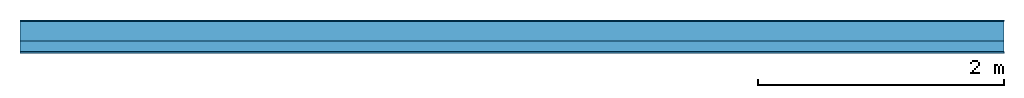
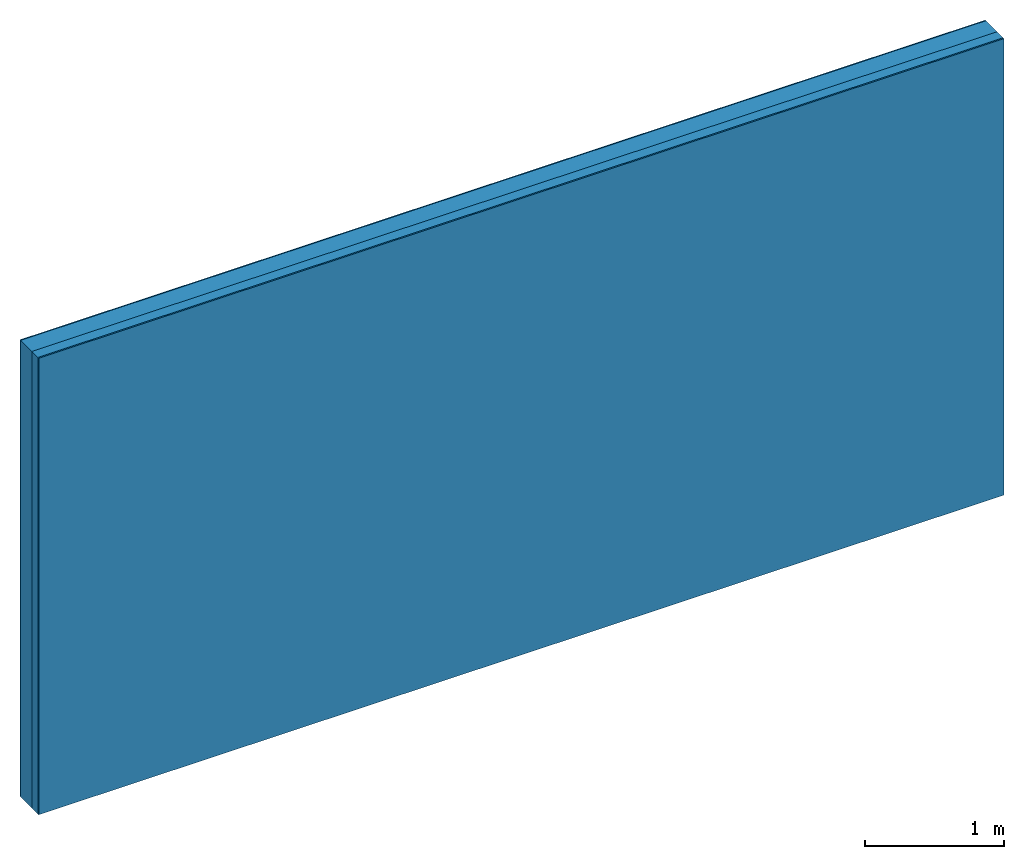
# One storey: 3 plates, 1 member, 1 element without a shape of its own.
"""IFC4 building model written with IfcOpenShell, lengths in metres."""

import ifcopenshell
import ifcopenshell.guid

model = None  # the IFC model being written
_history = None  # IfcOwnerHistory: only IFC2X3 demands one
_inside = {}  # id of a spatial element -> (the spatial element, [elements in it])
_under = {}  # id of a project, library or spatial element -> (it, [spatial elements below it])
_declared = {}  # id of a project -> (the project, [libraries it declares])
_typed = {}  # id of a type object -> (the type object, [elements of that type])
_made_of = {}  # id of a material, layer set ... -> (it, [elements and type objects made of it])


def new_model(schema):
    """Start an empty IFC model of exactly this schema.

    Asked for "IFC4X3", IfcOpenShell would pick the latest addendum, in which some entities
    have other attributes; the version numbers below select the first issue.
    IFC2X3 requires an IfcOwnerHistory on every rooted entity: one is made here for all.
    """
    global model, _history
    if schema == "IFC4X3":
        model = ifcopenshell.file(schema_version=(4, 3, 0, 0))
    else:
        model = ifcopenshell.file(schema=schema)
    _inside.clear()
    _under.clear()
    _declared.clear()
    _typed.clear()
    _made_of.clear()
    _history = None
    if model.schema == "IFC2X3":
        org = make("IfcOrganization", Name="unknown")
        user = make(
            "IfcPersonAndOrganization",
            ThePerson=make("IfcPerson", FamilyName="unknown"),
            TheOrganization=org,
        )
        app = make(
            "IfcApplication",
            ApplicationDeveloper=org,
            Version="unknown",
            ApplicationFullName="unknown",
            ApplicationIdentifier="unknown",
        )
        _history = make(
            "IfcOwnerHistory",
            OwningUser=user,
            OwningApplication=app,
            ChangeAction="ADDED",
            CreationDate=0,
        )
    return model


def make(cls, **values):
    """One entity of the class cls with the attributes given. An attribute that is None is left unset."""
    return model.create_entity(
        cls, **{name: value for name, value in values.items() if value is not None}
    )


def rooted(cls, **values):
    """An entity with a GlobalId (a new one), such as an element, a storey or a relation."""
    return make(cls, GlobalId=ifcopenshell.guid.new(), OwnerHistory=_history, **values)


def si_unit(unit_type, name, prefix=None):
    """IfcSIUnit, for example si_unit("LENGTHUNIT", "METRE", prefix="MILLI")."""
    return make("IfcSIUnit", UnitType=unit_type, Prefix=prefix, Name=name)


def derived_unit(unit_type, elements):
    """IfcDerivedUnit: a product of units, each with its exponent."""
    return make(
        "IfcDerivedUnit",
        Elements=[
            make("IfcDerivedUnitElement", Unit=unit, Exponent=power)
            for unit, power in elements
        ],
        UnitType=unit_type,
    )


def assignment(units):
    """IfcUnitAssignment: the units of a project."""
    return None if units is None else make("IfcUnitAssignment", Units=units)


def point(xyz):
    """IfcCartesianPoint."""
    return None if xyz is None else make("IfcCartesianPoint", Coordinates=xyz)


def direction(xyz):
    """IfcDirection."""
    return None if xyz is None else make("IfcDirection", DirectionRatios=xyz)


def frame(location, z_axis=None, x_axis=None):
    """IfcAxis2Placement3D, a coordinate frame: its origin and axes. An axis left out is left unset."""
    return make(
        "IfcAxis2Placement3D",
        Location=point(location),
        Axis=direction(z_axis),
        RefDirection=direction(x_axis),
    )


def frame_2d(location, x_axis=None):
    """IfcAxis2Placement2D, a coordinate frame in the plane: its origin and x axis."""
    return make(
        "IfcAxis2Placement2D", Location=point(location), RefDirection=direction(x_axis)
    )


def origin():
    """The frame at (0, 0, 0) with its axes left unset."""
    return frame((0.0, 0.0, 0.0))


def origin_with_axes():
    """The frame at (0, 0, 0) with the z axis (0, 0, 1) and the x axis (1, 0, 0) written out."""
    return frame((0.0, 0.0, 0.0), z_axis=(0.0, 0.0, 1.0), x_axis=(1.0, 0.0, 0.0))


def place(relative_to, where):
    """IfcLocalPlacement: puts the frame where relative to a parent placement (None: the world)."""
    return make(
        "IfcLocalPlacement", PlacementRelTo=relative_to, RelativePlacement=where
    )


def context(
    kind, dimensions, precision=None, world=None, true_north=None, identifier=None
):
    """IfcGeometricRepresentationContext, for example the 3D "Model" context."""
    return make(
        "IfcGeometricRepresentationContext",
        ContextIdentifier=identifier,
        ContextType=kind,
        CoordinateSpaceDimension=dimensions,
        Precision=precision,
        WorldCoordinateSystem=world,
        TrueNorth=true_north,
    )


def project(units=None, contexts=None):
    """IfcProject with its units and contexts."""
    return rooted(
        "IfcProject",
        Name="project",
        RepresentationContexts=contexts,
        UnitsInContext=assignment(units),
    )


def spatial(cls, under=None, at=None, **own):
    """A site, building, storey or space (cls), placed at a placement, below another one or the project."""
    s = rooted(cls, ObjectPlacement=at, **own)
    if under is not None:
        _under.setdefault(under.id(), (under, []))[1].append(s)
    return s


def profile(cls, at=None, kind="AREA", **sizes):
    """A parametric profile (cls). Its sizes go by their IFC names, for example OverallWidth=200.0."""
    return make(cls, ProfileType=kind, Position=at, **sizes)


def rectangle(**sizes):
    """IfcRectangleProfileDef."""
    return profile("IfcRectangleProfileDef", **sizes)


def extrude(swept, where, along, depth):
    """IfcExtrudedAreaSolid: the profile swept, set in the frame where, extruded along a direction by depth."""
    return make(
        "IfcExtrudedAreaSolid",
        SweptArea=swept,
        Position=where,
        ExtrudedDirection=direction(along),
        Depth=depth,
    )


def shape(context_of_items, identifier, shape_type, items):
    """IfcShapeRepresentation: the items that make up one representation, for example the "Body"."""
    return make(
        "IfcShapeRepresentation",
        ContextOfItems=context_of_items,
        RepresentationIdentifier=identifier,
        RepresentationType=shape_type,
        Items=items,
    )


def material(Name=None, Category=None):
    """IfcMaterial."""
    return make("IfcMaterial", Name=Name, Category=Category)


def layer(
    of_material, thickness, ventilated=None, Name=None, Category=None, Priority=None
):
    """IfcMaterialLayer: one layer of a wall or slab, of a material (None: an air gap)."""
    return make(
        "IfcMaterialLayer",
        Material=of_material,
        LayerThickness=thickness,
        IsVentilated=ventilated,
        Name=Name,
        Category=Category,
        Priority=Priority,
    )


def layer_set(layers, Name=None):
    """IfcMaterialLayerSet."""
    return make("IfcMaterialLayerSet", MaterialLayers=layers, LayerSetName=Name)


def made_of(thing, what):
    """Note that an element or type object is made of a material, layer set ...; save() writes the relation."""
    if what is not None:
        _made_of.setdefault(what.id(), (what, []))[1].append(thing)
    return thing


def type_object(cls, material=None, **own):
    """A type object (cls), such as IfcWallType, which elements share."""
    return made_of(rooted(cls, **own), material)


def element(
    cls,
    number,
    at=None,
    inside=None,
    cuts=None,
    type_object=None,
    material=None,
    context=None,
    identifier="Body",
    shape_type=None,
    held_by="IfcProductDefinitionShape",
    body=None,
    shapes=None,
    **own,
):
    """One element of the class cls, such as IfcWall. Its Tag is "e" and its number.

    at: its placement. inside: the storey or other place that contains it. cuts: it is an
    opening in that element (IfcRelVoidsElement). A single representation is given by context,
    identifier, shape_type and body (its items); several are given by shapes. held_by: the class
    of the entity that holds the representations. save() writes the other relations.
    """
    e = rooted(cls, Tag="e%d" % number, ObjectPlacement=at, **own)
    if body is not None:
        shapes = [shape(context, identifier, shape_type, body)]
    if shapes is not None:
        e.Representation = make(held_by, Representations=shapes)
    if inside is not None:
        _inside.setdefault(inside.id(), (inside, []))[1].append(e)
    if cuts is not None:
        rooted(
            "IfcRelVoidsElement", RelatingBuildingElement=cuts, RelatedOpeningElement=e
        )
    if type_object is not None:
        _typed.setdefault(type_object.id(), (type_object, []))[1].append(e)
    return made_of(e, material)


def aggregate(whole, parts):
    """IfcRelAggregates: a whole, such as a stair, and the parts it consists of."""
    return rooted("IfcRelAggregates", RelatingObject=whole, RelatedObjects=parts)


def save(model, path):
    """Write the relations noted so far, then the file.

    IfcRelAggregates (storeys below a building ...), IfcRelContainedInSpatialStructure (elements
    in a storey), IfcRelDefinesByType, IfcRelAssociatesMaterial and IfcRelDeclares: one each for
    every whole, place, type object, material and project.
    """
    for whole, parts in _under.values():
        aggregate(whole, parts)
    for where, things in _inside.values():
        rooted(
            "IfcRelContainedInSpatialStructure",
            RelatedElements=things,
            RelatingStructure=where,
        )
    for kind, things in _typed.values():
        rooted("IfcRelDefinesByType", RelatedObjects=things, RelatingType=kind)
    for what, things in _made_of.values():
        rooted("IfcRelAssociatesMaterial", RelatedObjects=things, RelatingMaterial=what)
    for by, libraries in _declared.values():
        rooted("IfcRelDeclares", RelatingContext=by, RelatedDefinitions=libraries)
    model.write(path)


model = new_model("IFC4")

# Units and contexts
plan_context = context("Plan", 3, precision=1e-05, world=origin(), true_north=direction((0.0, 1.0)))
model_context = context("Model", 3, precision=1e-05, world=origin(), true_north=direction((0.0, 1.0)))
ifc_project = project(units=[si_unit("LENGTHUNIT", "METRE"), derived_unit("SOUNDPRESSUREUNIT", [(si_unit("PRESSUREUNIT", "PASCAL", prefix="MICRO"), 0)]), si_unit("ENERGYUNIT", "JOULE", prefix="MEGA"), si_unit("MASSUNIT", "GRAM", prefix="KILO"), derived_unit("THERMALTRANSMITTANCEUNIT", [(si_unit("POWERUNIT", "WATT"), 1), (si_unit("AREAUNIT", "SQUARE_METRE"), -1), (si_unit("THERMODYNAMICTEMPERATUREUNIT", "KELVIN"), -1)]), derived_unit("AREADENSITYUNIT", [(si_unit("MASSUNIT", "GRAM", prefix="KILO"), 1), (si_unit("AREAUNIT", "SQUARE_METRE"), -1)]), derived_unit("USERDEFINED", [(si_unit("ENERGYUNIT", "JOULE", prefix="MEGA"), 1), (si_unit("AREAUNIT", "SQUARE_METRE"), -1)])], contexts=[plan_context, model_context])

# Site, building, storey
site = spatial("IfcSite", under=ifc_project)
building_placement = place(None, origin())
building = spatial("IfcBuilding", under=site, at=building_placement)
storey_placement = place(building_placement, origin())
storey = spatial("IfcBuildingStorey", under=building, at=storey_placement)

# Wall, member, plates
ifc_material_1 = material(Category="04.011")
ifc_layer_1 = layer(ifc_material_1, 0.01, Name="Surface 1")
ifc_material_2 = material(Category="10.009")
ifc_layer_2 = layer(ifc_material_2, 0.16, Name="outside 1st layer")
ifc_material_3 = material(Name="of the art")
ifc_layer_3 = layer(ifc_material_3, 0.0, Name="Bond")
ifc_layer_4 = layer(None, 0.087, Name="Support")
ifc_layer_5 = layer(ifc_material_3, 0.0, Name="Bond")
ifc_material_4 = material(Name="Plasterboard type A", Category="03.008")
ifc_layer_6 = layer(ifc_material_4, 0.0125, Name="1st layer")
ifc_material_5 = material(Name="joints", Category="04.017")
ifc_layer_7 = layer(ifc_material_5, 0.0, Name="Surface")
ifc_layer_set = layer_set([ifc_layer_1, ifc_layer_2, ifc_layer_3, ifc_layer_4, ifc_layer_5, ifc_layer_6, ifc_layer_7])
wall_type = type_object("IfcWallType", Name="D1037", PredefinedType="NOTDEFINED", material=ifc_layer_set)
wall_placement = place(None, frame((0.0, 0.0, 0.0), z_axis=(0.0, -1.0, 0.0), x_axis=(1.0, 0.0, 0.0)))
wall = element("IfcWall", 1, at=wall_placement, inside=storey, type_object=wall_type, material=ifc_layer_set, Name="Wall #1")
ifc_material_6 = material(Name="Solid timber panel")
member_placement = place(wall_placement, origin())
member = element("IfcMember", 2, at=member_placement, material=ifc_material_6, Name="Support", context=plan_context, shape_type="SweptSolid", body=[
    extrude(rectangle(XDim=1.0, YDim=0.087, at=frame_2d((0.5, 0.0435), x_axis=(1.0, 0.0))), frame((0.0, 4.0, 0.17), z_axis=(0.0, -1.0, 0.0), x_axis=(1.0, 0.0, 0.0)), (0.0, 0.0, 1.0), 4.0),
    extrude(rectangle(XDim=1.0, YDim=0.087, at=frame_2d((0.5, 0.0435), x_axis=(1.0, 0.0))), frame((1.0, 4.0, 0.17), z_axis=(0.0, -1.0, 0.0), x_axis=(1.0, 0.0, 0.0)), (0.0, 0.0, 1.0), 4.0),
    extrude(rectangle(XDim=1.0, YDim=0.087, at=frame_2d((0.5, 0.0435), x_axis=(1.0, 0.0))), frame((2.0, 4.0, 0.17), z_axis=(0.0, -1.0, 0.0), x_axis=(1.0, 0.0, 0.0)), (0.0, 0.0, 1.0), 4.0),
    extrude(rectangle(XDim=1.0, YDim=0.087, at=frame_2d((0.5, 0.0435), x_axis=(1.0, 0.0))), frame((3.0, 4.0, 0.17), z_axis=(0.0, -1.0, 0.0), x_axis=(1.0, 0.0, 0.0)), (0.0, 0.0, 1.0), 4.0),
    extrude(rectangle(XDim=1.0, YDim=0.087, at=frame_2d((0.5, 0.0435), x_axis=(1.0, 0.0))), frame((4.0, 4.0, 0.17), z_axis=(0.0, -1.0, 0.0), x_axis=(1.0, 0.0, 0.0)), (0.0, 0.0, 1.0), 4.0),
    extrude(rectangle(XDim=1.0, YDim=0.087, at=frame_2d((0.5, 0.0435), x_axis=(1.0, 0.0))), frame((5.0, 4.0, 0.17), z_axis=(0.0, -1.0, 0.0), x_axis=(1.0, 0.0, 0.0)), (0.0, 0.0, 1.0), 4.0),
    extrude(rectangle(XDim=1.0, YDim=0.087, at=frame_2d((0.5, 0.0435), x_axis=(1.0, 0.0))), frame((6.0, 4.0, 0.17), z_axis=(0.0, -1.0, 0.0), x_axis=(1.0, 0.0, 0.0)), (0.0, 0.0, 1.0), 4.0),
    extrude(rectangle(XDim=1.0, YDim=0.087, at=frame_2d((0.5, 0.0435), x_axis=(1.0, 0.0))), frame((7.0, 4.0, 0.17), z_axis=(0.0, -1.0, 0.0), x_axis=(1.0, 0.0, 0.0)), (0.0, 0.0, 1.0), 4.0),
])
plate_1_placement = place(wall_placement, origin())
plate_1 = element("IfcPlate", 3, at=plate_1_placement, material=ifc_material_1, Name="Surface 1", context=plan_context, shape_type="SweptSolid", body=[
    extrude(rectangle(XDim=8.0, YDim=4.0, at=frame_2d((4.0, 2.0), x_axis=(1.0, 0.0))), origin_with_axes(), (0.0, 0.0, 1.0), 0.01),
])
plate_2_placement = place(wall_placement, origin())
plate_2 = element("IfcPlate", 4, at=plate_2_placement, material=ifc_material_2, Name="outside 1st layer", context=plan_context, shape_type="SweptSolid", body=[
    extrude(rectangle(XDim=8.0, YDim=4.0, at=frame_2d((4.0, 2.0), x_axis=(1.0, 0.0))), frame((0.0, 0.0, 0.01), z_axis=(0.0, 0.0, 1.0), x_axis=(1.0, 0.0, 0.0)), (0.0, 0.0, 1.0), 0.16),
])
plate_3_placement = place(wall_placement, origin())
plate_3 = element("IfcPlate", 5, at=plate_3_placement, material=ifc_material_4, Name="1st layer", context=plan_context, shape_type="SweptSolid", body=[
    extrude(rectangle(XDim=8.0, YDim=4.0, at=frame_2d((4.0, 2.0), x_axis=(1.0, 0.0))), frame((0.0, 0.0, 0.257), z_axis=(0.0, 0.0, 1.0), x_axis=(1.0, 0.0, 0.0)), (0.0, 0.0, 1.0), 0.0125),
])
aggregate(wall, [plate_1, plate_2, member, plate_3])

save(model, "model.ifc")
